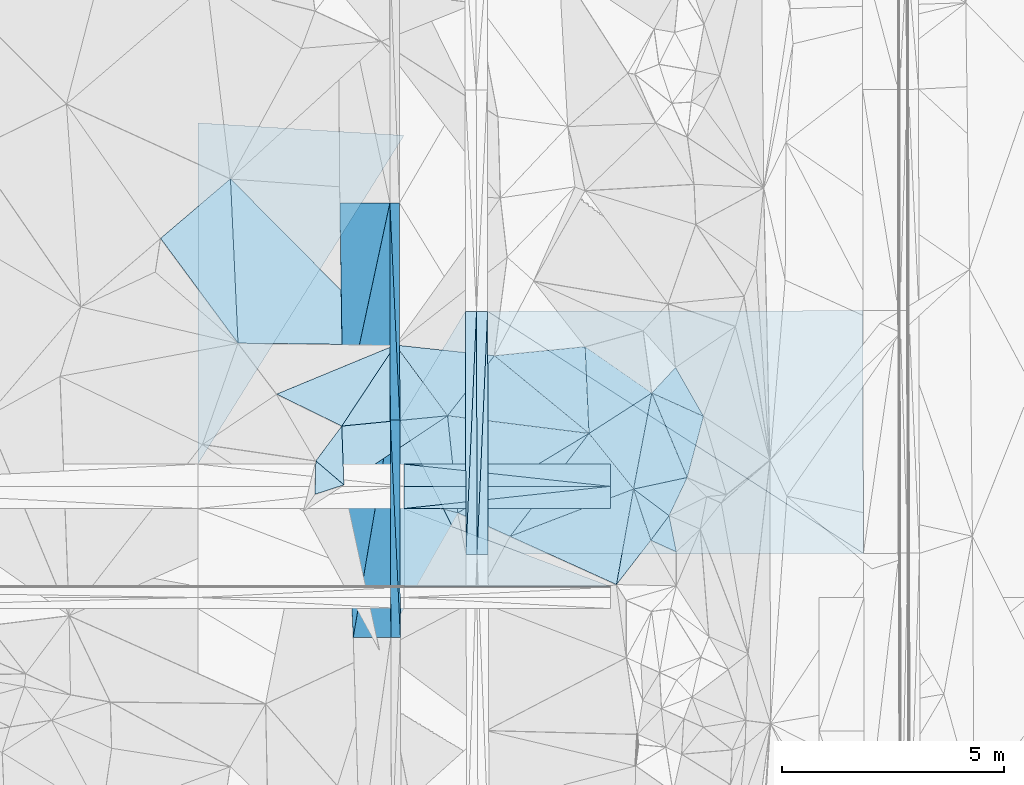
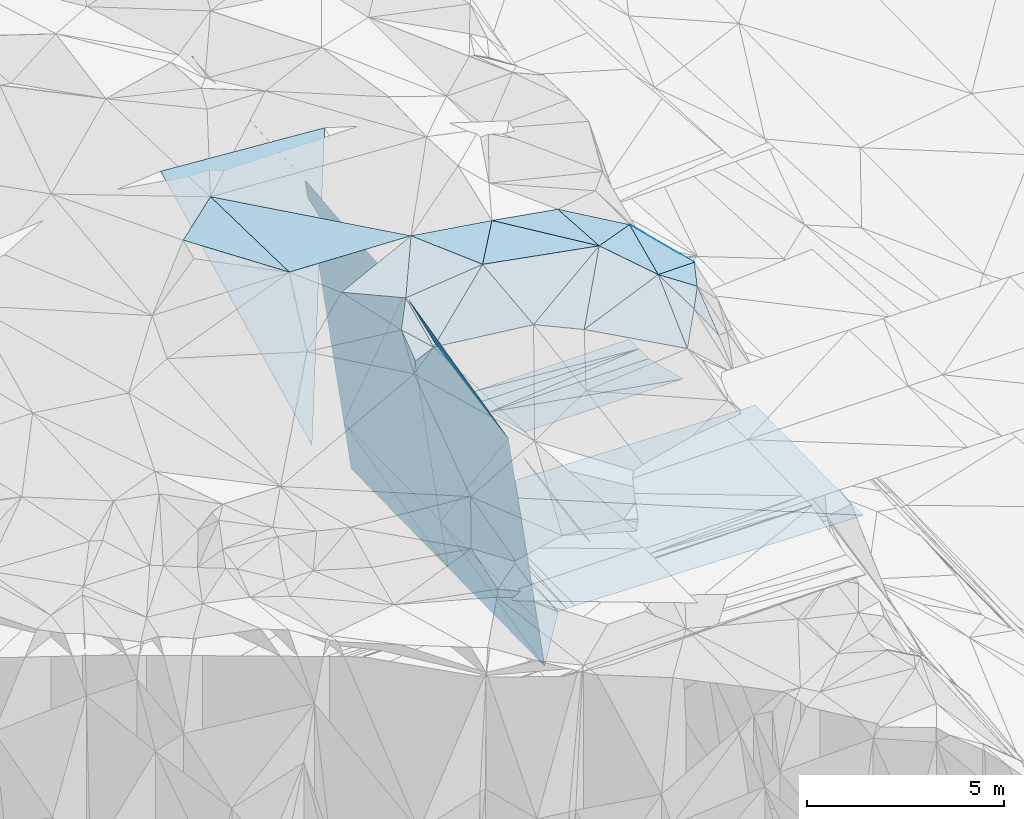
# One storey, part 78 of 275: 47 plates.
"""IFC2X3 building model written with IfcOpenShell, lengths in millimetres."""

from ifc_helpers import new_model, si_unit, frame, origin_with_axes, place, context, subcontext, project, spatial, polyline, outline, extrude, material, type_object, element, save


model = new_model("IFC2X3")

# Units and contexts
model_context = context("Model", 3, precision=1e-05, world=origin_with_axes())
body_context = subcontext(model_context, "Body", "Model", "MODEL_VIEW")
ifc_project = project(units=[si_unit("LENGTHUNIT", "METRE", prefix="MILLI"), si_unit("AREAUNIT", "SQUARE_METRE"), si_unit("VOLUMEUNIT", "CUBIC_METRE"), si_unit("MASSUNIT", "GRAM", prefix="KILO"), si_unit("TIMEUNIT", "SECOND"), si_unit("PLANEANGLEUNIT", "RADIAN"), si_unit("SOLIDANGLEUNIT", "STERADIAN"), si_unit("THERMODYNAMICTEMPERATUREUNIT", "DEGREE_CELSIUS"), si_unit("LUMINOUSINTENSITYUNIT", "LUMEN")], contexts=[model_context])

# Site, building, storey
site_placement = place(None, origin_with_axes())
site = spatial("IfcSite", under=ifc_project, at=site_placement, CompositionType="ELEMENT")
building_placement = place(site_placement, origin_with_axes())
building = spatial("IfcBuilding", under=site, at=building_placement, Name="Undefined", CompositionType="ELEMENT")
storey_placement = place(building_placement, origin_with_axes())
storey = spatial("IfcBuildingStorey", under=building, at=storey_placement, Name="Undefined", CompositionType="ELEMENT", Elevation=0.0)

# Plates
ifc_material = material()
plate_type_1 = type_object("IfcPlateType", PredefinedType="NOTDEFINED")
plate_1_placement = place(storey_placement, frame((-103838.324457377, 72730.0150090734, 42707.9307203099), z_axis=(0.0498772046312539, 0.0196889598778598, -0.998561269686092), x_axis=(0.00213500610633357, -0.999805487654526, -0.0196068509664852)))
element("IfcPlate", 1, at=plate_1_placement, inside=storey, type_object=plate_type_1, material=ifc_material, Name="00_PR", context=body_context, shape_type="SweptSolid", body=[
    extrude(outline(polyline([(0.0, 0.0), (5467.884765625, 2.4869223125279e-08), (5468.24365234375, 250.312057495117), (0.0, 0.0)])), frame((-8.85201319254618e-08, 2.18876761149539e-07, -0.5000001331573), z_axis=(0.0, 0.0, 1.0), x_axis=(1.0, 0.0, 0.0)), (0.0, 0.0, 1.0), 1.0),
])
plate_2_placement = place(storey_placement, frame((-104088.324494674, 72729.5941530452, 42695.4307208852), z_axis=(0.0498948682860124, 0.0196881709319733, -0.998560402801991), x_axis=(0.998750927650917, 0.00168131510243238, 0.0499375379445027)))
element("IfcPlate", 2, at=plate_2_placement, inside=storey, type_object=plate_type_1, material=ifc_material, Name="00_PR", context=body_context, shape_type="SweptSolid", body=[
    extrude(outline(polyline([(0.0, 0.0), (250.312698364258, -9.60426405072212e-10), (-2.88527274131775, 5468.11083984375), (0.0, 0.0)])), frame((-8.85201319254618e-08, 2.18876761149539e-07, -0.5000001331573), z_axis=(0.0, 0.0, 1.0), x_axis=(1.0, 0.0, 0.0)), (0.0, 0.0, 1.0), 1.0),
])
plate_3_placement = place(storey_placement, frame((-103826.685450437, 67263.1938574922, 42600.7221974995), z_axis=(-0.0200428106081081, 0.0195609821519625, -0.99960774993003), x_axis=(0.0435425309117292, 0.998877041328667, 0.0186736260080819)))
element("IfcPlate", 3, at=plate_3_placement, inside=storey, type_object=plate_type_1, material=ifc_material, Name="00_PR", context=body_context, shape_type="SweptSolid", body=[
    extrude(outline(polyline([(0.0, 0.0), (5473.3876953125, -2.89437593892217e-08), (11.4384937286377, 249.788650512695), (0.0, 0.0)])), frame((-8.85201319254618e-08, 2.18876761149539e-07, -0.5000001331573), z_axis=(0.0, 0.0, 1.0), x_axis=(1.0, 0.0, 0.0)), (0.0, 0.0, 1.0), 1.0),
])
plate_4_placement = place(storey_placement, frame((-103588.360282654, 72730.4354078092, 42702.9301966856), z_axis=(-0.0200251290373272, 0.0195602182677955, -0.999608119248916), x_axis=(-0.0435425308869583, -0.998877041330159, -0.0186736259860614)))
element("IfcPlate", 4, at=plate_4_placement, inside=storey, type_object=plate_type_1, material=ifc_material, Name="00_PR", context=body_context, shape_type="SweptSolid", body=[
    extrude(outline(polyline([(0.0, 0.0), (5473.3876953125, -2.89437593892217e-08), (11.2122049331665, 249.797973632813), (0.0, 0.0)])), frame((-8.85201319254618e-08, 2.18876761149539e-07, -0.5000001331573), z_axis=(0.0, 0.0, 1.0), x_axis=(1.0, 0.0, 0.0)), (0.0, 0.0, 1.0), 1.0),
])
plate_type_2 = type_object("IfcPlateType", PredefinedType="NOTDEFINED")
plate_5_placement = place(storey_placement, frame((-100306.504778326, 68730.9499759868, 50809.5297517334), z_axis=(-0.324497683131349, 0.100950592295268, -0.940484041096722), x_axis=(-0.598536231260992, 0.747996017902093, 0.286803655957346)))
element("IfcPlate", 5, at=plate_5_placement, inside=storey, type_object=plate_type_2, material=ifc_material, Name="00", context=body_context, shape_type="SweptSolid", body=[
    extrude(outline(polyline([(0.0, 0.0), (1673.61877441406, -6.13363226875663e-09), (1395.89733886719, 1702.40148925781), (0.0, 0.0)])), frame((-8.85201319254618e-08, 2.18876761149539e-07, -0.5000001331573), z_axis=(0.0, 0.0, 1.0), x_axis=(1.0, 0.0, 0.0)), (0.0, 0.0, 1.0), 1.0),
])
plate_type_3 = type_object("IfcPlateType", PredefinedType="NOTDEFINED")
for number, where, z_axis, x_axis, name in (
    (6, (-100830.116940968, 68792.6684019672, 48658.0050009023), (0.00445954401937214, -2.2587800795359e-06, -0.999990056181579), (-0.99422516846575, 0.107222448013454, -0.00443407614436219), "00_PR"),
    (7, (-105468.857562098, 69292.9344816128, 48637.3170000512), (0.00445954412724179, -2.55895633812821e-07, -0.999990056183616), (0.99422516846515, -0.10722244801891, 0.00443407614681367), "00_PR"),
):
    element("IfcPlate", number, at=place(storey_placement, frame(where, z_axis=z_axis, x_axis=x_axis)), inside=storey, type_object=plate_type_3, material=ifc_material, Name=name, context=body_context, shape_type="SweptSolid", body=[
        extrude(outline(polyline([(0.0, 0.0), (4665.68408203125, -2.39524524658918e-08), (53.5827484130859, 497.12060546875), (0.0, 0.0)])), frame((-8.85201319254618e-08, 2.18876761149539e-07, -0.5000001331573), z_axis=(0.0, 0.0, 1.0), x_axis=(1.0, 0.0, 0.0)), (0.0, 0.0, 1.0), 1.0),
    ])
for number, where, z_axis, x_axis, name in (
    (8, (-100830.116940968, 68792.6684019672, 48658.0050009023), (0.00445976024364945, 1.74411737731609e-06, -0.999990055218314), (-5.72919567491096e-05, -0.999999998356816, -2.00003991831675e-06), "00_PR"),
    (9, (-105468.914857222, 68292.9344750873, 48637.3170002161), (0.00445954412724179, -2.55895633812821e-07, -0.999990056183616), (5.72939566107594e-05, 0.999999998358701, 3.92465150362411e-11), "00_PR"),
):
    element("IfcPlate", number, at=place(storey_placement, frame(where, z_axis=z_axis, x_axis=x_axis)), inside=storey, type_object=plate_type_3, material=ifc_material, Name=name, context=body_context, shape_type="SweptSolid", body=[
        extrude(outline(polyline([(0.0, 0.0), (500.0, 8.00355337560177e-10), (499.999725341797, 4638.8154296875), (0.0, 0.0)])), frame((-8.85201319254618e-08, 2.18876761149539e-07, -0.5000001331573), z_axis=(0.0, 0.0, 1.0), x_axis=(1.0, 0.0, 0.0)), (0.0, 0.0, 1.0), 1.0),
    ])
plate_type_4 = type_object("IfcPlateType", PredefinedType="NOTDEFINED")
plate_6_placement = place(storey_placement, frame((-100306.377195293, 68731.088325233, 50809.5383188683), z_axis=(-0.0693286074895092, 0.377648124628633, -0.923350116774803), x_axis=(0.295809391203479, -0.876167801726551, -0.380561147903317)))
element("IfcPlate", 10, at=plate_6_placement, inside=storey, type_object=plate_type_4, material=ifc_material, Name="00", context=body_context, shape_type="SweptSolid", body=[
    extrude(outline(polyline([(0.0, 0.0), (1313.84936523438, -1.05355866253376e-08), (2092.55346679688, 1052.72021484375), (0.0, 0.0)])), frame((-8.85201319254618e-08, 2.18876761149539e-07, -0.5000001331573), z_axis=(0.0, 0.0, 1.0), x_axis=(1.0, 0.0, 0.0)), (0.0, 0.0, 1.0), 1.0),
])
plate_type_5 = type_object("IfcPlateType", PredefinedType="NOTDEFINED")
plate_7_placement = place(storey_placement, frame((-106820.644230948, 68825.1605162859, 50789.5635485118), z_axis=(-0.0254782165712802, 0.487254550685203, -0.872888230712792), x_axis=(-0.0324274752934652, 0.872309346356317, 0.487877918239294)))
element("IfcPlate", 11, at=plate_7_placement, inside=storey, type_object=plate_type_5, material=ifc_material, Name="00", context=body_context, shape_type="SweptSolid", body=[
    extrude(outline(polyline([(0.0, 0.0), (1516.77294921875, -9.26957000046968e-09), (1671.1796875, 2386.453125), (0.0, 0.0)])), frame((-8.85201319254618e-08, 2.18876761149539e-07, -0.5000001331573), z_axis=(0.0, 0.0, 1.0), x_axis=(1.0, 0.0, 0.0)), (0.0, 0.0, 1.0), 1.0),
])
plate_type_6 = type_object("IfcPlateType", PredefinedType="NOTDEFINED")
plate_8_placement = place(storey_placement, frame((-105786.738944094, 75167.7674103866, 44243.3752892675), z_axis=(-0.989948937859716, 0.00109331755697326, -0.141421020669276), x_axis=(-0.11856776394694, -0.551489668937171, 0.825712316977403)))
element("IfcPlate", 12, at=plate_8_placement, inside=storey, type_object=plate_type_6, material=ifc_material, Name="00_PR", context=body_context, shape_type="SweptSolid", body=[
    extrude(outline(polyline([(0.0, 0.0), (8862.1474609375, 3.54921212419868e-08), (6647.29638671875, 4392.90185546875), (0.0, 0.0)])), frame((-8.85201319254618e-08, 2.18876761149539e-07, -0.5000001331573), z_axis=(0.0, 0.0, 1.0), x_axis=(1.0, 0.0, 0.0)), (0.0, 0.0, 1.0), 1.0),
])
plate_type_7 = type_object("IfcPlateType", PredefinedType="NOTDEFINED")
plate_9_placement = place(storey_placement, frame((-106837.503910865, 70280.3848483462, 51560.9592897131), z_axis=(-0.989948995716399, 0.00109394363074064, -0.141420610829631), x_axis=(0.11856776395032, 0.551489668939534, -0.82571231697534)))
element("IfcPlate", 13, at=plate_9_placement, inside=storey, type_object=plate_type_7, material=ifc_material, Name="00_PR", context=body_context, shape_type="SweptSolid", body=[
    extrude(outline(polyline([(0.0, 0.0), (8862.1474609375, 3.54921212419868e-08), (6247.70068359375, 4127.79931640625), (0.0, 0.0)])), frame((-8.85201319254618e-08, 2.18876761149539e-07, -0.5000001331573), z_axis=(0.0, 0.0, 1.0), x_axis=(1.0, 0.0, 0.0)), (0.0, 0.0, 1.0), 1.0),
])
plate_type_8 = type_object("IfcPlateType", PredefinedType="NOTDEFINED")
plate_10_placement = place(storey_placement, frame((-105778.521229258, 70282.5950979225, 44148.0622896661), z_axis=(-0.989949505223216, 0.000319124440081517, -0.141420915242058), x_axis=(-0.108952290934386, -0.639268771852491, 0.761225876881729)))
element("IfcPlate", 14, at=plate_10_placement, inside=storey, type_object=plate_type_8, material=ifc_material, Name="00_PR", context=body_context, shape_type="SweptSolid", body=[
    extrude(outline(polyline([(0.0, 0.0), (7645.630859375, -2.81288521364331e-08), (5759.6806640625, 4785.24462890625), (0.0, 0.0)])), frame((-8.85201319254618e-08, 2.18876761149539e-07, -0.5000001331573), z_axis=(0.0, 0.0, 1.0), x_axis=(1.0, 0.0, 0.0)), (0.0, 0.0, 1.0), 1.0),
])
plate_type_9 = type_object("IfcPlateType", PredefinedType="NOTDEFINED")
plate_11_placement = place(storey_placement, frame((-105786.738944094, 75167.7674103866, 44243.3752892675), z_axis=(-0.989948995716399, 0.00109394363074064, -0.141420610829631), x_axis=(0.141420881996339, 0.000180223976161713, -0.98994954500454)))
element("IfcPlate", 15, at=plate_11_placement, inside=storey, type_object=plate_type_9, material=ifc_material, Name="00_PR", context=body_context, shape_type="SweptSolid", body=[
    extrude(outline(polyline([(0.0, 0.0), (1515.22875976563, -2.92493496090174e-09), (1609.86560058594, 4885.01806640625), (0.0, 0.0)])), frame((-8.85201319254618e-08, 2.18876761149539e-07, -0.5000001331573), z_axis=(0.0, 0.0, 1.0), x_axis=(1.0, 0.0, 0.0)), (0.0, 0.0, 1.0), 1.0),
])
plate_12_placement = place(storey_placement, frame((-105552.060412223, 65398.0520778292, 42551.793290086), z_axis=(-0.989949505223216, 0.000319124440081517, -0.141420915242058), x_axis=(-0.141421116993174, -0.000409797980036631, 0.989949443019197)))
element("IfcPlate", 16, at=plate_12_placement, inside=storey, type_object=plate_type_9, material=ifc_material, Name="00_PR", context=body_context, shape_type="SweptSolid", body=[
    extrude(outline(polyline([(0.0, 0.0), (1515.22888183594, -4.05998434871435e-09), (1610.25024414063, 4885.20361328125), (0.0, 0.0)])), frame((-8.85201319254618e-08, 2.18876761149539e-07, -0.5000001331573), z_axis=(0.0, 0.0, 1.0), x_axis=(1.0, 0.0, 0.0)), (0.0, 0.0, 1.0), 1.0),
])
plate_13_placement = place(storey_placement, frame((-105778.521229258, 70282.5950979225, 44148.0622896661), z_axis=(-0.989949505223216, 0.000319124440081517, -0.141420915242058), x_axis=(0.141421296001557, 0.000295144010628987, -0.989949458269084)))
element("IfcPlate", 17, at=plate_13_placement, inside=storey, type_object=plate_type_9, material=ifc_material, Name="00_PR", context=body_context, shape_type="SweptSolid", body=[
    extrude(outline(polyline([(0.0, 0.0), (1515.22888183594, -4.05998434871435e-09), (1610.81042480469, 4885.01904296875), (0.0, 0.0)])), frame((-8.85201319254618e-08, 2.18876761149539e-07, -0.5000001331573), z_axis=(0.0, 0.0, 1.0), x_axis=(1.0, 0.0, 0.0)), (0.0, 0.0, 1.0), 1.0),
])
plate_14_placement = place(storey_placement, frame((-105564.235605678, 70283.0426943053, 42648.0622904128), z_axis=(-0.989948937859716, 0.00109331755697326, -0.141421020669276), x_axis=(-0.141421296008809, -0.000295144009284462, 0.989949458268048)))
element("IfcPlate", 18, at=plate_14_placement, inside=storey, type_object=plate_type_9, material=ifc_material, Name="00_PR", context=body_context, shape_type="SweptSolid", body=[
    extrude(outline(polyline([(0.0, 0.0), (1515.22888183594, -4.05998434871435e-09), (1609.30419921875, 4885.20263671875), (0.0, 0.0)])), frame((-8.85201319254618e-08, 2.18876761149539e-07, -0.5000001331573), z_axis=(0.0, 0.0, 1.0), x_axis=(1.0, 0.0, 0.0)), (0.0, 0.0, 1.0), 1.0),
])
plate_type_10 = type_object("IfcPlateType", PredefinedType="NOTDEFINED")
plate_15_placement = place(storey_placement, frame((-106611.530218204, 65394.9820921179, 49968.1142902992), z_axis=(-0.989949505223216, 0.000319124440081517, -0.141420915242058), x_axis=(0.108952290924048, 0.639268771859645, -0.7612258768772)))
element("IfcPlate", 19, at=plate_15_placement, inside=storey, type_object=plate_type_10, material=ifc_material, Name="00_PR", context=body_context, shape_type="SweptSolid", body=[
    extrude(outline(polyline([(0.0, 0.0), (7645.630859375, -2.81288521364331e-08), (4597.30712890625, 3818.63403320313), (0.0, 0.0)])), frame((-8.85201319254618e-08, 2.18876761149539e-07, -0.5000001331573), z_axis=(0.0, 0.0, 1.0), x_axis=(1.0, 0.0, 0.0)), (0.0, 0.0, 1.0), 1.0),
])
plate_type_11 = type_object("IfcPlateType", PredefinedType="NOTDEFINED")
plate_16_placement = place(storey_placement, frame((-105551.565401377, 65398.061767982, 42551.3640982071), z_axis=(7.73186365668472e-05, 0.0197034687316775, -0.999805864826651), x_axis=(-0.00249187510319716, 0.999802767488516, 0.019703214985726)))
element("IfcPlate", 20, at=plate_16_placement, inside=storey, type_object=plate_type_11, material=ifc_material, Name="00_PR", context=body_context, shape_type="SweptSolid", body=[
    extrude(outline(polyline([(0.0, 0.0), (4885.9541015625, -1.56142050400376e-08), (1861.16748046875, 1479.533203125), (0.0, 0.0)])), frame((-8.85201319254618e-08, 2.18876761149539e-07, -0.5000001331573), z_axis=(0.0, 0.0, 1.0), x_axis=(1.0, 0.0, 0.0)), (0.0, 0.0, 1.0), 1.0),
])
plate_type_12 = type_object("IfcPlateType", PredefinedType="NOTDEFINED")
plate_17_placement = place(storey_placement, frame((-105563.740691678, 70283.0519492102, 42647.6330971552), z_axis=(-0.000121093817220948, 0.0196058237707746, -0.99980778003102), x_axis=(0.516343685961226, 0.856218072128757, 0.0167275499727147)))
element("IfcPlate", 21, at=plate_17_placement, inside=storey, type_object=plate_type_12, material=ifc_material, Name="00_PR", context=body_context, shape_type="SweptSolid", body=[
    extrude(outline(polyline([(0.0, 0.0), (2857.38208007813, -2.2409949451685e-09), (-1819.36840820313, 2833.41674804688), (0.0, 0.0)])), frame((-8.85201319254618e-08, 2.18876761149539e-07, -0.5000001331573), z_axis=(0.0, 0.0, 1.0), x_axis=(1.0, 0.0, 0.0)), (0.0, 0.0, 1.0), 1.0),
])
plate_type_13 = type_object("IfcPlateType", PredefinedType="NOTDEFINED")
plate_18_placement = place(storey_placement, frame((-103588.360282654, 72730.4354078092, 42702.9301966856), z_axis=(-0.0200267588675458, 0.0195891735804533, -0.999607519583409), x_axis=(0.999798585053685, 0.00170321912438076, -0.019997209036844)))
element("IfcPlate", 22, at=plate_18_placement, inside=storey, type_object=plate_type_13, material=ifc_material, Name="00_PR", context=body_context, shape_type="SweptSolid", body=[
    extrude(outline(polyline([(0.0, 0.0), (8442.8779296875, 9.31322574615479e-10), (8447.4970703125, 5460.0029296875), (0.0, 0.0)])), frame((-8.85201319254618e-08, 2.18876761149539e-07, -0.5000001331573), z_axis=(0.0, 0.0, 1.0), x_axis=(1.0, 0.0, 0.0)), (0.0, 0.0, 1.0), 1.0),
])
plate_type_14 = type_object("IfcPlateType", PredefinedType="NOTDEFINED")
plate_19_placement = place(storey_placement, frame((-95135.4080189212, 67285.876129665, 42426.882196246), z_axis=(-0.0200449268555272, 0.0195609772143698, -0.999607707592221), x_axis=(-0.999796620689094, -0.00260989113274427, 0.0199976430346725)))
element("IfcPlate", 23, at=plate_19_placement, inside=storey, type_object=plate_type_14, material=ifc_material, Name="00_PR", context=body_context, shape_type="SweptSolid", body=[
    extrude(outline(polyline([(0.0, 0.0), (8442.9951171875, -4.58239810541272e-08), (8442.5439453125, 5467.658203125), (0.0, 0.0)])), frame((-8.85201319254618e-08, 2.18876761149539e-07, -0.5000001331573), z_axis=(0.0, 0.0, 1.0), x_axis=(1.0, 0.0, 0.0)), (0.0, 0.0, 1.0), 1.0),
])
plate_type_15 = type_object("IfcPlateType", PredefinedType="NOTDEFINED")
plate_20_placement = place(storey_placement, frame((-105664.062592878, 71971.3438620425, 51919.5107519188), z_axis=(0.00456885130786253, 0.206281890683153, -0.978481940136818), x_axis=(0.585465180137781, -0.793808671755965, -0.164615659921122)))
element("IfcPlate", 24, at=plate_20_placement, inside=storey, type_object=plate_type_15, material=ifc_material, Name="00", context=body_context, shape_type="SweptSolid", body=[
    extrude(outline(polyline([(0.0, 0.0), (2004.66955566406, 1.04919308796525e-08), (805.569152832031, 2069.09594726563), (0.0, 0.0)])), frame((-8.85201319254618e-08, 2.18876761149539e-07, -0.5000001331573), z_axis=(0.0, 0.0, 1.0), x_axis=(1.0, 0.0, 0.0)), (0.0, 0.0, 1.0), 1.0),
])
plate_type_16 = type_object("IfcPlateType", PredefinedType="NOTDEFINED")
for number, where, z_axis, x_axis, name in (
    (25, (-100830.245926322, 66542.5471185431, 49095.5189293266), (0.00431248448580711, -0.242533600329647, -0.970133421333735), (-0.999990054538875, 5.7357962472799e-05, -0.00445954408009802), "00_PR"),
    (26, (-105468.914930635, 68292.8132060362, 48637.3319284891), (0.00431248448580711, -0.242533600329647, -0.970133421333735), (0.999990054538811, -5.7357974325105e-05, 0.00445954409423353), "00_PR"),
):
    element("IfcPlate", number, at=place(storey_placement, frame(where, z_axis=z_axis, x_axis=x_axis)), inside=storey, type_object=plate_type_16, material=ifc_material, Name=name, context=body_context, shape_type="SweptSolid", body=[
        extrude(outline(polyline([(0.0, 0.0), (4638.8154296875, -1.62399373948574e-08), (4640.7666015625, 1803.85766601563), (0.0, 0.0)])), frame((-8.85201319254618e-08, 2.18876761149539e-07, -0.5000001331573), z_axis=(0.0, 0.0, 1.0), x_axis=(1.0, 0.0, 0.0)), (0.0, 0.0, 1.0), 1.0),
    ])
plate_type_17 = type_object("IfcPlateType", PredefinedType="NOTDEFINED")
plate_21_placement = place(storey_placement, frame((-110107.626813704, 69293.4237541579, 48604.7267896201), z_axis=(0.0063195673830604, 0.447204327533506, -0.894409499336515), x_axis=(5.12609174268665e-05, 0.894427213806252, 0.447213546949446)))
element("IfcPlate", 27, at=plate_21_placement, inside=storey, type_object=plate_type_17, material=ifc_material, Name="00_PR", context=body_context, shape_type="SweptSolid", body=[
    extrude(outline(polyline([(0.0, 0.0), (8580.154296875, -3.65107553079724e-08), (8280.7529296875, 4638.86181640625), (0.0, 0.0)])), frame((-8.85201319254618e-08, 2.18876761149539e-07, -0.5000001331573), z_axis=(0.0, 0.0, 1.0), x_axis=(1.0, 0.0, 0.0)), (0.0, 0.0, 1.0), 1.0),
])
plate_type_18 = type_object("IfcPlateType", PredefinedType="NOTDEFINED")
plate_22_placement = place(storey_placement, frame((-107453.237616633, 69365.5461119586, 51219.5692967707), z_axis=(-0.179699637828018, 0.475091635398294, -0.861391884184576), x_axis=(0.569544197849405, 0.764204389205275, 0.30267318714328)))
element("IfcPlate", 28, at=plate_22_placement, inside=storey, type_object=plate_type_18, material=ifc_material, Name="00", context=body_context, shape_type="SweptSolid", body=[
    extrude(outline(polyline([(0.0, 0.0), (1024.20703125, -3.87080945074558e-09), (-182.873184204102, 918.453796386719), (0.0, 0.0)])), frame((-8.85201319254618e-08, 2.18876761149539e-07, -0.5000001331573), z_axis=(0.0, 0.0, 1.0), x_axis=(1.0, 0.0, 0.0)), (0.0, 0.0, 1.0), 1.0),
])
plate_type_19 = type_object("IfcPlateType", PredefinedType="NOTDEFINED")
plate_23_placement = place(storey_placement, frame((-99895.2909244514, 70891.6765639801, 50899.6502492712), z_axis=(-0.690873064922324, -0.182782051575663, -0.699489192044184), x_axis=(0.714190482008091, -0.322917108737602, -0.621012476761617)))
element("IfcPlate", 29, at=plate_23_placement, inside=storey, type_object=plate_type_19, material=ifc_material, Name="00", context=body_context, shape_type="SweptSolid", body=[
    extrude(outline(polyline([(0.0, 0.0), (1626.37634277344, 1.11540430225432e-08), (1362.47680664063, 1572.56384277344), (0.0, 0.0)])), frame((-8.85201319254618e-08, 2.18876761149539e-07, -0.5000001331573), z_axis=(0.0, 0.0, 1.0), x_axis=(1.0, 0.0, 0.0)), (0.0, 0.0, 1.0), 1.0),
])
plate_type_20 = type_object("IfcPlateType", PredefinedType="NOTDEFINED")
plate_24_placement = place(storey_placement, frame((-99506.5056754286, 68133.4118171403, 50529.5187603196), z_axis=(-0.199162120458983, 0.184366681760869, -0.962467337851404), x_axis=(-0.771383709486864, 0.576250004043268, 0.270005751009898)))
element("IfcPlate", 30, at=plate_24_placement, inside=storey, type_object=plate_type_20, material=ifc_material, Name="00", context=body_context, shape_type="SweptSolid", body=[
    extrude(outline(polyline([(0.0, 0.0), (1037.01489257813, 8.0999598139897e-09), (201.540008544922, 931.977294921875), (0.0, 0.0)])), frame((-8.85201319254618e-08, 2.18876761149539e-07, -0.5000001331573), z_axis=(0.0, 0.0, 1.0), x_axis=(1.0, 0.0, 0.0)), (0.0, 0.0, 1.0), 1.0),
])
plate_type_21 = type_object("IfcPlateType", PredefinedType="NOTDEFINED")
plate_25_placement = place(storey_placement, frame((-110945.279004452, 74370.7426514217, 52179.5008781163), z_axis=(-0.0454423250518966, 0.0384169511941203, -0.998227996479174), x_axis=(0.761016101703893, 0.648660768046117, -0.00967992485671467)))
element("IfcPlate", 31, at=plate_25_placement, inside=storey, type_object=plate_type_21, material=ifc_material, Name="00", context=body_context, shape_type="SweptSolid", body=[
    extrude(outline(polyline([(0.0, 0.0), (2066.13159179688, -1.16124283522367e-08), (-201.729644775391, 2928.720703125), (0.0, 0.0)])), frame((-8.85201319254618e-08, 2.18876761149539e-07, -0.5000001331573), z_axis=(0.0, 0.0, 1.0), x_axis=(1.0, 0.0, 0.0)), (0.0, 0.0, 1.0), 1.0),
])
plate_type_22 = type_object("IfcPlateType", PredefinedType="NOTDEFINED")
plate_26_placement = place(storey_placement, frame((-101308.107019155, 69982.9077123174, 51289.5243340529), z_axis=(-0.0859646783489239, 0.295975987781302, -0.951319235973524), x_axis=(0.598536231253723, -0.747996017909018, -0.286803655954455)))
element("IfcPlate", 32, at=plate_26_placement, inside=storey, type_object=plate_type_22, material=ifc_material, Name="00", context=body_context, shape_type="SweptSolid", body=[
    extrude(outline(polyline([(0.0, 0.0), (1673.61877441406, -6.13363226875663e-09), (830.057556152344, 2852.75390625), (0.0, 0.0)])), frame((-8.85201319254618e-08, 2.18876761149539e-07, -0.5000001331573), z_axis=(0.0, 0.0, 1.0), x_axis=(1.0, 0.0, 0.0)), (0.0, 0.0, 1.0), 1.0),
])
plate_type_23 = type_object("IfcPlateType", PredefinedType="NOTDEFINED")
plate_27_placement = place(storey_placement, frame((-98733.7475974929, 70366.4984101726, 49889.6477768618), z_axis=(-0.689210253827685, -0.169596112635219, -0.704433378395573), x_axis=(-0.714190481999542, 0.322917108752829, 0.621012476763531)))
element("IfcPlate", 33, at=plate_27_placement, inside=storey, type_object=plate_type_23, material=ifc_material, Name="00", context=body_context, shape_type="SweptSolid", body=[
    extrude(outline(polyline([(0.0, 0.0), (1626.37634277344, 1.11540430225432e-08), (1021.28881835938, 827.024230957031), (0.0, 0.0)])), frame((-8.85201319254618e-08, 2.18876761149539e-07, -0.5000001331573), z_axis=(0.0, 0.0, 1.0), x_axis=(1.0, 0.0, 0.0)), (0.0, 0.0, 1.0), 1.0),
])
plate_type_24 = type_object("IfcPlateType", PredefinedType="NOTDEFINED")
plate_28_placement = place(storey_placement, frame((-101308.190697019, 69982.7491530692, 51289.5164174739), z_axis=(-0.253319250034163, -0.0211428412569551, -0.967151662266944), x_axis=(-0.0442927552182217, 0.99896614294265, -0.0102370449576395)))
element("IfcPlate", 34, at=plate_28_placement, inside=storey, type_object=plate_type_24, material=ifc_material, Name="00", context=body_context, shape_type="SweptSolid", body=[
    extrude(outline(polyline([(0.0, 0.0), (1953.68884277344, 7.5524440035224e-09), (849.469970703125, 1501.23303222656), (0.0, 0.0)])), frame((-8.85201319254618e-08, 2.18876761149539e-07, -0.5000001331573), z_axis=(0.0, 0.0, 1.0), x_axis=(1.0, 0.0, 0.0)), (0.0, 0.0, 1.0), 1.0),
])
plate_type_25 = type_object("IfcPlateType", PredefinedType="NOTDEFINED")
plate_29_placement = place(storey_placement, frame((-104490.427138686, 70379.9992355507, 51589.5075718852), z_axis=(-0.052956091825933, 0.165173838471977, -0.984841741308195), x_axis=(-0.585465180123707, 0.793808671765492, 0.164615659925234)))
element("IfcPlate", 35, at=plate_29_placement, inside=storey, type_object=plate_type_25, material=ifc_material, Name="00", context=body_context, shape_type="SweptSolid", body=[
    extrude(outline(polyline([(0.0, 0.0), (2004.66955566406, 1.04919308796525e-08), (483.920166015625, 1652.54992675781), (0.0, 0.0)])), frame((-8.85201319254618e-08, 2.18876761149539e-07, -0.5000001331573), z_axis=(0.0, 0.0, 1.0), x_axis=(1.0, 0.0, 0.0)), (0.0, 0.0, 1.0), 1.0),
])
plate_type_26 = type_object("IfcPlateType", PredefinedType="NOTDEFINED")
plate_30_placement = place(storey_placement, frame((-100306.358259017, 68731.0941202355, 50809.5396938914), z_axis=(-0.0314612939299518, 0.389238156375015, -0.920599720077099), x_axis=(0.771383709487851, -0.576250004040911, -0.270005751012107)))
element("IfcPlate", 36, at=plate_30_placement, inside=storey, type_object=plate_type_26, material=ifc_material, Name="00", context=body_context, shape_type="SweptSolid", body=[
    extrude(outline(polyline([(0.0, 0.0), (1037.01489257813, 8.0999598139897e-09), (1098.15197753906, 721.292053222656), (0.0, 0.0)])), frame((-8.85201319254618e-08, 2.18876761149539e-07, -0.5000001331573), z_axis=(0.0, 0.0, 1.0), x_axis=(1.0, 0.0, 0.0)), (0.0, 0.0, 1.0), 1.0),
])
plate_type_27 = type_object("IfcPlateType", PredefinedType="NOTDEFINED")
plate_31_placement = place(storey_placement, frame((-99098.6712736389, 68991.5408945889, 50609.5094606687), z_axis=(-0.178614825037475, 0.0748669387649954, -0.981066606177578), x_axis=(-0.964943273608587, -0.208210176147564, 0.159790491788916)))
element("IfcPlate", 37, at=plate_31_placement, inside=storey, type_object=plate_type_27, material=ifc_material, Name="00", context=body_context, shape_type="SweptSolid", body=[
    extrude(outline(polyline([(0.0, 0.0), (1251.63891601563, 7.71251507103443e-10), (419.130462646484, 2038.04553222656), (0.0, 0.0)])), frame((-8.85201319254618e-08, 2.18876761149539e-07, -0.5000001331573), z_axis=(0.0, 0.0, 1.0), x_axis=(1.0, 0.0, 0.0)), (0.0, 0.0, 1.0), 1.0),
])
plate_type_28 = type_object("IfcPlateType", PredefinedType="NOTDEFINED")
plate_32_placement = place(storey_placement, frame((-101308.099179389, 69982.8488512615, 51289.5092579571), z_axis=(-0.0702775565308482, 0.178253641575745, -0.981471703266599), x_axis=(-0.987988896900351, 0.123301422752301, 0.0931380628362367)))
element("IfcPlate", 38, at=plate_32_placement, inside=storey, type_object=plate_type_28, material=ifc_material, Name="00", context=body_context, shape_type="SweptSolid", body=[
    extrude(outline(polyline([(0.0, 0.0), (3221.02465820313, -1.9834260456264e-08), (2362.60229492188, 1492.71923828125), (0.0, 0.0)])), frame((-8.85201319254618e-08, 2.18876761149539e-07, -0.5000001331573), z_axis=(0.0, 0.0, 1.0), x_axis=(1.0, 0.0, 0.0)), (0.0, 0.0, 1.0), 1.0),
])
plate_type_29 = type_object("IfcPlateType", PredefinedType="NOTDEFINED")
plate_33_placement = place(storey_placement, frame((-105664.088928673, 71971.3603448218, 51919.5151097262), z_axis=(-0.0480950994486139, 0.239245870206219, -0.96976712410676), x_axis=(-0.543037760665265, -0.821132564932679, -0.175645385076678)))
element("IfcPlate", 39, at=plate_33_placement, inside=storey, type_object=plate_type_29, material=ifc_material, Name="00", context=body_context, shape_type="SweptSolid", body=[
    extrude(outline(polyline([(0.0, 0.0), (2220.3828125, 4.27826307713985e-09), (2382.29174804688, 1643.55883789063), (0.0, 0.0)])), frame((-8.85201319254618e-08, 2.18876761149539e-07, -0.5000001331573), z_axis=(0.0, 0.0, 1.0), x_axis=(1.0, 0.0, 0.0)), (0.0, 0.0, 1.0), 1.0),
])
plate_type_30 = type_object("IfcPlateType", PredefinedType="NOTDEFINED")
plate_34_placement = place(storey_placement, frame((-109203.497476843, 72013.7465602419, 52009.5005360776), z_axis=(-0.0249274939614993, 0.0393847677662528, -0.998913139423443), x_axis=(-0.0457358902427787, 0.998132435286024, 0.0404953080454052)))
element("IfcPlate", 40, at=plate_34_placement, inside=storey, type_object=plate_type_30, material=ifc_material, Name="00", context=body_context, shape_type="SweptSolid", body=[
    extrude(outline(polyline([(0.0, 0.0), (3704.1328125, 6.73753675073385e-09), (-207.929901123047, 3534.70874023438), (0.0, 0.0)])), frame((-8.85201319254618e-08, 2.18876761149539e-07, -0.5000001331573), z_axis=(0.0, 0.0, 1.0), x_axis=(1.0, 0.0, 0.0)), (0.0, 0.0, 1.0), 1.0),
])
plate_type_31 = type_object("IfcPlateType", PredefinedType="NOTDEFINED")
plate_35_placement = place(storey_placement, frame((-99343.790574261, 67320.0194349141, 49449.7226078883), z_axis=(-0.54701925271347, 0.626895298846061, -0.554772224832412), x_axis=(-0.538498227915628, 0.243882582721515, 0.806561184521554)))
element("IfcPlate", 41, at=plate_35_placement, inside=storey, type_object=plate_type_31, material=ifc_material, Name="00", context=body_context, shape_type="SweptSolid", body=[
    extrude(outline(polyline([(0.0, 0.0), (1066.25512695313, 3.12502379529178e-09), (1157.22778320313, 718.139282226563), (0.0, 0.0)])), frame((-8.85201319254618e-08, 2.18876761149539e-07, -0.5000001331573), z_axis=(0.0, 0.0, 1.0), x_axis=(1.0, 0.0, 0.0)), (0.0, 0.0, 1.0), 1.0),
])
plate_type_32 = type_object("IfcPlateType", PredefinedType="NOTDEFINED")
plate_36_placement = place(storey_placement, frame((-104490.332541298, 70380.0587071315, 51589.5254616823), z_axis=(0.136231527786597, 0.284115189193093, -0.94906244794887), x_axis=(0.101852771256981, -0.956934079821707, -0.271851392976119)))
element("IfcPlate", 42, at=plate_36_placement, inside=storey, type_object=plate_type_32, material=ifc_material, Name="00", context=body_context, shape_type="SweptSolid", body=[
    extrude(outline(polyline([(0.0, 0.0), (2280.65771484375, -1.01863406598568e-09), (1468.1728515625, 2516.43969726563), (0.0, 0.0)])), frame((-8.85201319254618e-08, 2.18876761149539e-07, -0.5000001331573), z_axis=(0.0, 0.0, 1.0), x_axis=(1.0, 0.0, 0.0)), (0.0, 0.0, 1.0), 1.0),
])
plate_type_33 = type_object("IfcPlateType", PredefinedType="NOTDEFINED")
plate_37_placement = place(storey_placement, frame((-101308.097840793, 69982.9013238126, 51289.5216558459), z_axis=(-0.0676109542496274, 0.283199657286583, -0.956674820917859), x_axis=(-0.597535238929984, -0.779374803314739, -0.188484891158413)))
element("IfcPlate", 43, at=plate_37_placement, inside=storey, type_object=plate_type_33, material=ifc_material, Name="00", context=body_context, shape_type="SweptSolid", body=[
    extrude(outline(polyline([(0.0, 0.0), (2971.06030273438, 4.62750904262066e-09), (3214.47509765625, 1288.23498535156), (0.0, 0.0)])), frame((-8.85201319254618e-08, 2.18876761149539e-07, -0.5000001331573), z_axis=(0.0, 0.0, 1.0), x_axis=(1.0, 0.0, 0.0)), (0.0, 0.0, 1.0), 1.0),
])
plate_type_34 = type_object("IfcPlateType", PredefinedType="NOTDEFINED")
plate_38_placement = place(storey_placement, frame((-100690.361656524, 66582.3532158944, 49959.5422233265), z_axis=(-0.120605072923152, 0.383721009621707, -0.915539514799934), x_axis=(-0.874002614325011, 0.396275740880134, 0.281220495951036)))
element("IfcPlate", 44, at=plate_38_placement, inside=storey, type_object=plate_type_34, material=ifc_material, Name="00", context=body_context, shape_type="SweptSolid", body=[
    extrude(outline(polyline([(0.0, 0.0), (2738.06494140625, -4.20550350099802e-09), (754.94921875, 2217.44262695313), (0.0, 0.0)])), frame((-8.85201319254618e-08, 2.18876761149539e-07, -0.5000001331573), z_axis=(0.0, 0.0, 1.0), x_axis=(1.0, 0.0, 0.0)), (0.0, 0.0, 1.0), 1.0),
])
plate_type_35 = type_object("IfcPlateType", PredefinedType="NOTDEFINED")
plate_39_placement = place(storey_placement, frame((-104258.138024603, 68197.6110800775, 50969.5190134311), z_axis=(-0.0573395380641644, 0.267170966157472, -0.961941709365527), x_axis=(-0.101852771222914, 0.956934079864866, 0.27185139283696)))
element("IfcPlate", 45, at=plate_39_placement, inside=storey, type_object=plate_type_35, material=ifc_material, Name="00", context=body_context, shape_type="SweptSolid", body=[
    extrude(outline(polyline([(0.0, 0.0), (2280.65771484375, -1.01863406598568e-09), (1494.91955566406, 3123.71826171875), (0.0, 0.0)])), frame((-8.85201319254618e-08, 2.18876761149539e-07, -0.5000001331573), z_axis=(0.0, 0.0, 1.0), x_axis=(1.0, 0.0, 0.0)), (0.0, 0.0, 1.0), 1.0),
])
plate_type_36 = type_object("IfcPlateType", PredefinedType="NOTDEFINED")
plate_40_placement = place(storey_placement, frame((-106820.676665125, 68825.1935249631, 50789.5859262157), z_axis=(-0.0903153904457776, 0.553234797402871, -0.828114961337634), x_axis=(-0.946255972625867, -0.306957123085056, -0.101867359135395)))
element("IfcPlate", 46, at=plate_40_placement, inside=storey, type_object=plate_type_36, material=ifc_material, Name="00", context=body_context, shape_type="SweptSolid", body=[
    extrude(outline(polyline([(0.0, 0.0), (687.168090820313, 5.82076609134674e-11), (388.842254638672, 851.93994140625), (0.0, 0.0)])), frame((-8.85201319254618e-08, 2.18876761149539e-07, -0.5000001331573), z_axis=(0.0, 0.0, 1.0), x_axis=(1.0, 0.0, 0.0)), (0.0, 0.0, 1.0), 1.0),
])
plate_type_37 = type_object("IfcPlateType", PredefinedType="NOTDEFINED")
plate_41_placement = place(storey_placement, frame((-103436.977852246, 71731.2971852684, 51759.5136558147), z_axis=(-0.231358139287414, -0.0202255474094189, -0.972658387419476), x_axis=(0.967886695379368, 0.0962649991914728, -0.232224879886443)))
element("IfcPlate", 47, at=plate_41_placement, inside=storey, type_object=plate_type_37, material=ifc_material, Name="00", context=body_context, shape_type="SweptSolid", body=[
    extrude(outline(polyline([(0.0, 0.0), (2110.02368164063, 6.11180439591408e-10), (2001.25720214844, 1950.65881347656), (0.0, 0.0)])), frame((-8.85201319254618e-08, 2.18876761149539e-07, -0.5000001331573), z_axis=(0.0, 0.0, 1.0), x_axis=(1.0, 0.0, 0.0)), (0.0, 0.0, 1.0), 1.0),
])

save(model, "model.ifc")
